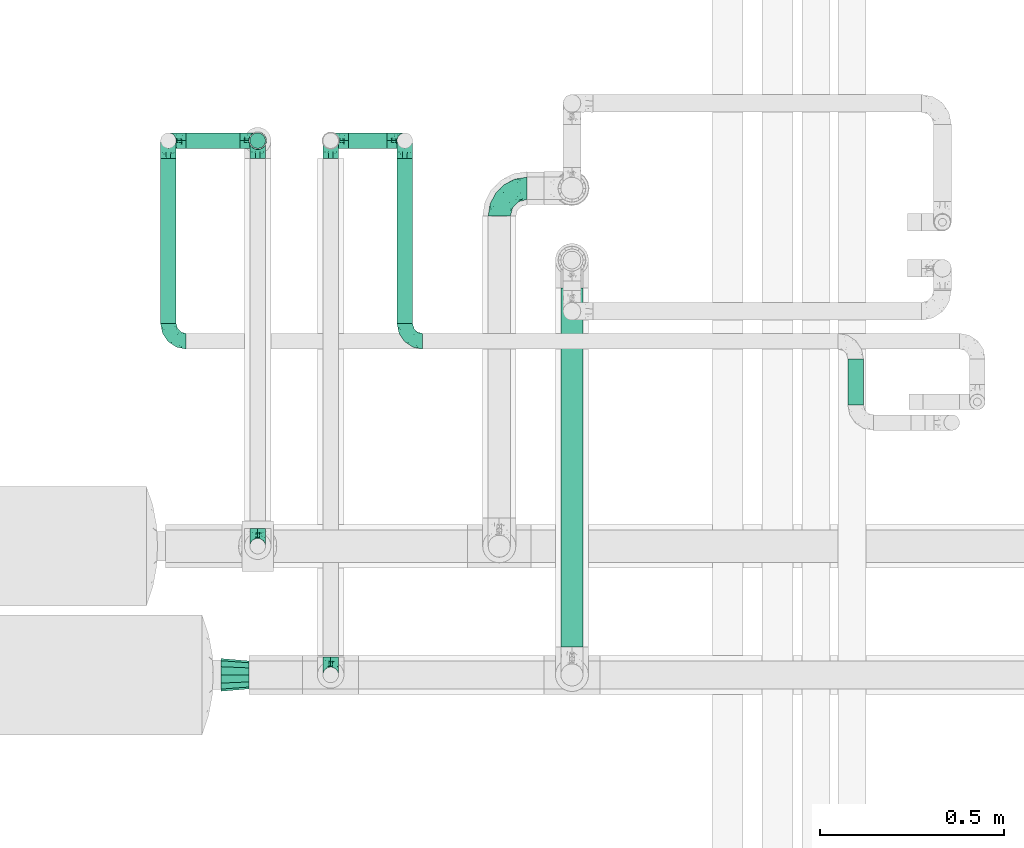
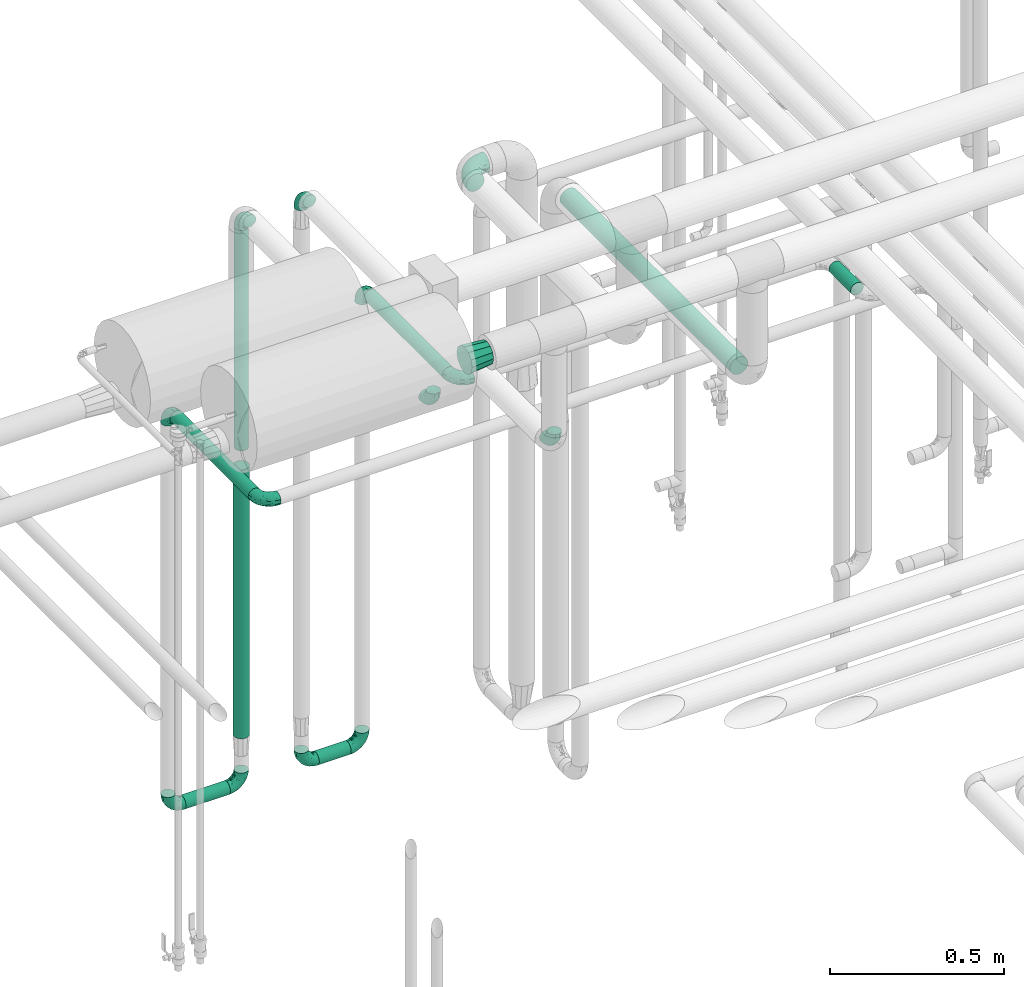
# One storey, part 573 of 824: 14 flow fittings, 8 flow segments.
"""IFC2X3 building model written with IfcOpenShell, lengths in millimetres."""

from ifc_helpers import new_model, entity, si_unit, converted_unit, derived_unit, direction, frame, origin, origin_2d_with_axis, place, context, subcontext, project, spatial, circle, extrude, faceted_brep, source, transform, mapped, material, type_object, type_shapes, element, save


model = new_model("IFC2X3")

# Units and contexts
model_context = context("Model", 3, precision=0.01, world=origin(), true_north=direction((6.12303176911189e-17, 1.0)))
body_context = subcontext(model_context, "Body", "Model", "MODEL_VIEW")
ifc_project = project(units=[si_unit("LENGTHUNIT", "METRE", prefix="MILLI"), si_unit("AREAUNIT", "SQUARE_METRE"), si_unit("VOLUMEUNIT", "CUBIC_METRE"), converted_unit("PLANEANGLEUNIT", "DEGREE", entity("IfcRatioMeasure", 0.0174532925199433), si_unit("PLANEANGLEUNIT", "RADIAN"), dimensions=[0, 0, 0, 0, 0, 0, 0]), si_unit("MASSUNIT", "GRAM", prefix="KILO"), derived_unit("MASSDENSITYUNIT", [(si_unit("MASSUNIT", "GRAM", prefix="KILO"), 1), (si_unit("LENGTHUNIT", "METRE"), -3)]), derived_unit("MOMENTOFINERTIAUNIT", [(si_unit("LENGTHUNIT", "METRE"), 4)]), si_unit("TIMEUNIT", "SECOND"), si_unit("FREQUENCYUNIT", "HERTZ"), si_unit("THERMODYNAMICTEMPERATUREUNIT", "DEGREE_CELSIUS"), derived_unit("THERMALTRANSMITTANCEUNIT", [(si_unit("MASSUNIT", "GRAM", prefix="KILO"), 1), (si_unit("THERMODYNAMICTEMPERATUREUNIT", "KELVIN"), -1), (si_unit("TIMEUNIT", "SECOND"), -3)]), derived_unit("VOLUMETRICFLOWRATEUNIT", [(si_unit("LENGTHUNIT", "METRE"), 3), (si_unit("TIMEUNIT", "SECOND"), -1)]), derived_unit("MASSFLOWRATEUNIT", [(si_unit("MASSUNIT", "GRAM", prefix="KILO"), 1), (si_unit("TIMEUNIT", "SECOND"), -1)]), derived_unit("ROTATIONALFREQUENCYUNIT", [(si_unit("TIMEUNIT", "SECOND"), -1)]), si_unit("ELECTRICCURRENTUNIT", "AMPERE"), si_unit("ELECTRICVOLTAGEUNIT", "VOLT"), si_unit("POWERUNIT", "WATT"), si_unit("FORCEUNIT", "NEWTON", prefix="KILO"), si_unit("ILLUMINANCEUNIT", "LUX"), si_unit("LUMINOUSFLUXUNIT", "LUMEN"), si_unit("LUMINOUSINTENSITYUNIT", "CANDELA"), derived_unit("USERDEFINED", [(si_unit("MASSUNIT", "GRAM", prefix="KILO"), -1), (si_unit("LENGTHUNIT", "METRE"), -2), (si_unit("TIMEUNIT", "SECOND"), 3), (si_unit("LUMINOUSFLUXUNIT", "LUMEN"), 1)]), derived_unit("LINEARVELOCITYUNIT", [(si_unit("LENGTHUNIT", "METRE"), 1), (si_unit("TIMEUNIT", "SECOND"), -1)]), si_unit("PRESSUREUNIT", "PASCAL"), derived_unit("USERDEFINED", [(si_unit("LENGTHUNIT", "METRE"), -2), (si_unit("MASSUNIT", "GRAM", prefix="KILO"), 1), (si_unit("TIMEUNIT", "SECOND"), -2)]), derived_unit("LINEARFORCEUNIT", [(si_unit("MASSUNIT", "GRAM", prefix="KILO"), 1), (si_unit("LENGTHUNIT", "METRE"), 1), (si_unit("TIMEUNIT", "SECOND"), -2), (si_unit("LENGTHUNIT", "METRE"), -1)]), derived_unit("PLANARFORCEUNIT", [(si_unit("MASSUNIT", "GRAM", prefix="KILO"), 1), (si_unit("LENGTHUNIT", "METRE"), 1), (si_unit("TIMEUNIT", "SECOND"), -2), (si_unit("LENGTHUNIT", "METRE"), -2)])], contexts=[model_context])

# Site, building, storey
site_placement = place(None, origin())
site = spatial("IfcSite", under=ifc_project, at=site_placement, CompositionType="ELEMENT")
building_placement = place(site_placement, origin())
building = spatial("IfcBuilding", under=site, at=building_placement, CompositionType="ELEMENT")
storey_placement = place(building_placement, frame((0.0, 0.0, 28200.0)))
storey = spatial("IfcBuildingStorey", under=building, at=storey_placement, CompositionType="ELEMENT", Elevation=28200.0)

# Flow segments
pipe_segment_type = type_object("IfcPipeSegmentType", PredefinedType="NOTDEFINED")
flow_segment_1_placement = place(storey_placement, frame((17314.71, 15829.04, 381.11)))
element("IfcFlowSegment", 1, at=flow_segment_1_placement, inside=storey, type_object=pipe_segment_type, context=body_context, shape_type="SweptSolid", body=[
    extrude(circle(Radius=21.15, at=origin_2d_with_axis()), frame((0.0, 22.75, 22.75), z_axis=(1.0, 0.0, 0.0), x_axis=(0.0, -1.0, 0.0)), (0.0, 0.0, 1.0), 105.488840849872),
])
flow_segment_2_placement = place(storey_placement, frame((16873.63, 15829.04, 381.19)))
element("IfcFlowSegment", 2, at=flow_segment_2_placement, inside=storey, type_object=pipe_segment_type, context=body_context, shape_type="SweptSolid", body=[
    extrude(circle(Radius=21.15, at=origin_2d_with_axis()), frame((0.0, 22.75, 22.75), z_axis=(1.0, 0.0, 0.0), x_axis=(0.0, -1.0, 0.0)), (0.0, 0.0, 1.0), 146.73003738029),
])
flow_segment_3_placement = place(storey_placement, frame((18670.46, 15133.74, 1977.25)))
element("IfcFlowSegment", 3, at=flow_segment_3_placement, inside=storey, type_object=pipe_segment_type, context=body_context, shape_type="SweptSolid", body=[
    extrude(circle(Radius=21.15, at=origin_2d_with_axis()), frame((22.75, 0.0, 22.75), z_axis=(0.0, 1.0, 0.0), x_axis=(-1.0, 0.0, 0.0)), (0.0, 0.0, 1.0), 125.041289846792),
])
flow_segment_4_placement = place(storey_placement, frame((17045.62, 15829.04, 1580.0)))
element("IfcFlowSegment", 4, at=flow_segment_4_placement, inside=storey, type_object=pipe_segment_type, context=body_context, shape_type="SweptSolid", body=[
    extrude(circle(Radius=21.15, at=origin_2d_with_axis()), frame((22.75, 22.75, 0.0)), (0.0, 0.0, 1.0), 772.000000000002),
])
flow_segment_5_placement = place(storey_placement, frame((17890.7, 14476.0, 2368.4)))
element("IfcFlowSegment", 5, at=flow_segment_5_placement, inside=storey, type_object=pipe_segment_type, context=body_context, shape_type="SweptSolid", body=[
    extrude(circle(Radius=30.0, at=origin_2d_with_axis()), frame((31.6, 0.0, 31.6), z_axis=(0.0, 1.0, 0.0), x_axis=(-1.0, 0.0, 0.0)), (0.0, 0.0, 1.0), 975.249133388721),
])
flow_segment_6_placement = place(storey_placement, frame((17042.77, 15826.19, 574.2)))
element("IfcFlowSegment", 6, at=flow_segment_6_placement, inside=storey, type_object=pipe_segment_type, context=body_context, shape_type="SweptSolid", body=[
    extrude(circle(Radius=24.0, at=origin_2d_with_axis()), frame((25.6, 25.6, 0.0)), (0.0, 0.0, 1.0), 941.79999999999),
])
flow_segment_7_placement = place(storey_placement, frame((17445.46, 15354.79, 1977.25)))
element("IfcFlowSegment", 7, at=flow_segment_7_placement, inside=storey, type_object=pipe_segment_type, context=body_context, shape_type="SweptSolid", body=[
    extrude(circle(Radius=21.15, at=origin_2d_with_axis()), frame((22.75, 0.0, 22.75), z_axis=(0.0, 1.0, 0.0), x_axis=(1.0, 0.0, 0.0)), (0.0, 0.0, 1.0), 448.999348960777),
])
flow_segment_8_placement = place(storey_placement, frame((16802.89, 15354.79, 1777.25)))
element("IfcFlowSegment", 8, at=flow_segment_8_placement, inside=storey, type_object=pipe_segment_type, context=body_context, shape_type="SweptSolid", body=[
    extrude(circle(Radius=21.15, at=origin_2d_with_axis()), frame((22.75, 0.0, 22.75), z_axis=(0.0, 1.0, 0.0), x_axis=(1.0, 0.0, 0.0)), (0.0, 0.0, 1.0), 448.999348960775),
])

# Flow fittings
ifc_material = material()
pipe_fitting_type_1 = type_object("IfcPipeFittingType", PredefinedType="NOTDEFINED", material=ifc_material)
shared_shape_1 = source(origin(), body_context, "Body", "Brep", [
    faceted_brep([(-48.0, 10.6, -18.36), (-48.0, 5.49, -20.48), (-48.0, 0.0, -21.2), (-48.0, -5.49, -20.48), (-48.0, -10.6, -18.36), (-48.0, -14.99, -14.99), (-48.0, -18.36, -10.6), (-48.0, -20.48, -5.49), (-48.0, -21.2, 0.0), (-48.0, -20.48, 5.49), (-48.0, -18.36, 10.6), (-48.0, -14.99, 14.99), (-48.0, -10.6, 18.36), (-48.0, -5.49, 20.48), (-48.0, 0.0, 21.2), (-48.0, 5.49, 20.48), (-48.0, 10.6, 18.36), (-48.0, 14.99, 14.99), (-48.0, 18.36, 10.6), (-48.0, 20.48, 5.49), (-48.0, 21.2, 0.0), (-48.0, 20.48, -5.49), (-48.0, 18.36, -10.6), (-48.0, 14.99, -14.99), (0.0, 48.0, -21.2), (-5.49, 48.0, -20.48), (-10.6, 48.0, -18.36), (-14.99, 48.0, -14.99), (-18.36, 48.0, -10.6), (-20.48, 48.0, -5.49), (-21.2, 48.0, 0.0), (-20.48, 48.0, 5.49), (-18.36, 48.0, 10.6), (-14.99, 48.0, 14.99), (-10.6, 48.0, 18.36), (-5.49, 48.0, 20.48), (0.0, 48.0, 21.2), (5.49, 48.0, 20.48), (10.6, 48.0, 18.36), (14.99, 48.0, 14.99), (18.36, 48.0, 10.6), (20.48, 48.0, 5.49), (21.2, 48.0, 0.0), (20.48, 48.0, -5.49), (18.36, 48.0, -10.6), (14.99, 48.0, -14.99), (10.6, 48.0, -18.36), (5.49, 48.0, -20.48), (-35.25, -16.22, 12.01), (-34.76, -18.57, 0.0), (-20.87, -12.37, 10.9), (-31.49, -11.78, 15.9), (-37.0, -2.58, 20.86), (-33.89, 3.62, 21.15), (-31.81, -18.14, 6.76), (-5.78, 5.78, 17.67), (-19.42, -4.1, 17.86), (-9.6, -3.39, 13.73), (-35.44, -7.73, 19.13), (11.78, 31.49, 15.9), (-5.93, -5.46, 6.95), (-18.45, -13.78, 5.46), (-10.29, -8.43, 0.0), (-24.6, 0.55, 20.62), (-37.28, 17.94, 13.81), (-33.38, 22.85, 9.59), (-41.46, 20.06, 8.75), (-29.51, 20.45, 15.16), (-15.04, 10.79, 21.13), (-7.08, 16.98, 20.93), (-8.39, 23.51, 21.15), (-40.86, 13.03, 17.26), (-8.05, 41.26, 19.83), (-3.21, 35.97, 21.14), (8.53, 19.66, 14.74), (4.1, 19.42, 17.86), (-37.72, 22.66, 4.78), (-37.07, 8.58, 19.98), (-13.0, 5.43, 19.97), (-3.78, 13.93, 19.7), (3.02, 8.69, 13.43), (-2.27, -0.05, 10.65), (6.22, 6.99, 7.09), (-22.25, 34.6, 9.45), (18.14, 31.81, 6.76), (16.22, 35.25, 12.01), (12.37, 20.87, 10.9), (7.73, 35.44, 19.13), (-21.52, -15.93, 0.0), (2.58, 37.0, 20.86), (18.57, 34.76, 0.0), (13.78, 18.45, 5.46), (15.93, 21.52, 0.0), (-20.03, -8.54, 14.9), (-28.6, 28.6, 5.16), (-24.79, 34.6, 0.0), (-34.6, 24.79, 0.0), (-22.81, 37.41, 4.68), (-23.36, 26.33, 14.79), (-13.68, 37.05, 17.49), (-17.72, 38.12, 13.73), (-26.25, 27.3, 11.24), (-9.71, 32.34, 20.14), (-17.26, 25.6, 18.71), (-26.33, 9.99, 20.77), (-24.06, 6.05, 21.2), (-25.02, 15.46, 19.56), (-24.3, 20.72, 17.57), (-31.95, 15.23, 17.8), (-13.53, 24.7, 20.21), (-17.6, 17.6, 20.6), (-0.55, 24.6, 20.62), (-11.41, -7.48, 10.43), (0.93, -0.93, 0.0), (8.43, 10.29, 0.0), (-11.41, -7.48, -10.43), (-20.1, -8.84, -14.66), (-9.6, -3.39, -13.73), (7.73, 35.44, -19.13), (4.1, 19.42, -17.86), (-0.55, 24.6, -20.62), (-38.12, 17.72, -13.73), (-37.05, 13.68, -17.49), (-32.34, 9.71, -20.14), (-41.26, 8.05, -19.83), (-37.41, 22.81, -4.68), (-23.51, 8.39, -21.15), (-35.97, 3.21, -21.14), (-28.6, 28.6, -5.16), (-31.81, -18.14, -6.76), (-18.45, -13.78, -5.46), (-25.6, 17.26, -18.71), (-19.42, -4.1, -17.86), (-17.94, 37.28, -13.81), (-22.85, 33.38, -9.59), (-20.06, 41.46, -8.75), (-31.49, -11.78, -15.9), (-35.25, -16.22, -12.01), (8.53, 19.66, -14.74), (11.78, 31.49, -15.9), (-9.99, 26.33, -20.77), (-6.05, 24.06, -21.2), (-10.79, 15.04, -21.13), (-37.0, -2.58, -20.86), (-16.98, 7.08, -20.93), (-5.43, 13.0, -19.97), (-13.93, 3.78, -19.7), (-20.87, -12.37, -10.9), (-26.33, 23.36, -14.79), (-22.66, 37.72, -4.78), (13.78, 18.45, -5.46), (18.14, 31.81, -6.76), (-15.46, 25.02, -19.56), (-20.72, 24.3, -17.57), (16.22, 35.25, -12.01), (-13.03, 40.86, -17.26), (-8.58, 37.07, -19.98), (2.58, 37.0, -20.86), (-3.62, 33.89, -21.15), (-34.6, 22.25, -9.45), (6.22, 6.99, -7.09), (-20.45, 29.51, -15.16), (-35.44, -7.73, -19.13), (12.37, 20.87, -10.9), (-27.3, 26.25, -11.24), (-15.23, 31.95, -17.8), (-24.7, 13.53, -20.21), (-24.6, 0.55, -20.62), (-5.78, 5.78, -17.67), (-17.6, 17.6, -20.6), (3.02, 8.69, -13.43), (-5.93, -5.46, -6.95), (-2.27, -0.05, -10.65)], [[[0, 1, 2, 3, 4, 5, 6, 7, 8, 9, 10, 11, 12, 13, 14, 15, 16, 17, 18, 19, 20, 21, 22, 23]], [[24, 25, 26, 27, 28, 29, 30, 31, 32, 33, 34, 35, 36, 37, 38, 39, 40, 41, 42, 43, 44, 45, 46, 47]], [[10, 48, 11]], [[9, 8, 49]], [[48, 50, 51]], [[14, 52, 53]], [[10, 54, 48]], [[9, 54, 10]], [[55, 56, 57]], [[51, 12, 11]], [[51, 58, 12]], [[59, 39, 38]], [[60, 61, 62]], [[58, 56, 63]], [[64, 65, 66]], [[67, 65, 64]], [[68, 69, 70]], [[16, 71, 17]], [[13, 52, 14]], [[35, 72, 73]], [[14, 53, 15]], [[17, 64, 18]], [[74, 59, 75]], [[20, 19, 76]], [[66, 19, 18]], [[77, 15, 53]], [[15, 77, 16]], [[69, 78, 79]], [[80, 81, 82]], [[32, 31, 83]], [[84, 85, 86]], [[59, 87, 75]], [[61, 54, 88]], [[36, 89, 37]], [[84, 41, 40]], [[36, 35, 73]], [[90, 41, 84]], [[40, 39, 85]], [[12, 58, 13]], [[85, 84, 40]], [[91, 84, 86]], [[84, 92, 90]], [[87, 38, 37]], [[93, 56, 51]], [[65, 94, 76]], [[94, 95, 96]], [[84, 91, 92]], [[95, 97, 30]], [[98, 99, 100]], [[76, 94, 96]], [[101, 98, 83]], [[100, 99, 33]], [[102, 70, 73]], [[103, 102, 99]], [[94, 97, 95]], [[72, 99, 102]], [[72, 35, 34]], [[34, 33, 99]], [[9, 49, 54]], [[87, 59, 38]], [[104, 105, 68]], [[106, 103, 107]], [[106, 77, 104]], [[71, 64, 17]], [[108, 107, 67]], [[33, 32, 100]], [[109, 103, 110]], [[102, 109, 70]], [[89, 73, 111]], [[50, 48, 54]], [[51, 11, 48]], [[56, 58, 51]], [[88, 54, 49]], [[52, 58, 63]], [[50, 112, 93]], [[56, 55, 78]], [[39, 59, 85]], [[86, 85, 59]], [[89, 87, 37]], [[42, 41, 90]], [[111, 79, 75]], [[111, 75, 87]], [[75, 55, 80]], [[104, 77, 53]], [[71, 77, 108]], [[32, 83, 100]], [[98, 100, 83]], [[99, 98, 103]], [[106, 107, 108]], [[68, 70, 110]], [[111, 73, 70]], [[68, 110, 104]], [[68, 63, 78]], [[57, 93, 112]], [[80, 55, 57]], [[61, 50, 54]], [[80, 82, 86]], [[81, 57, 112]], [[74, 86, 59]], [[60, 113, 82]], [[82, 114, 91]], [[101, 94, 65]], [[97, 94, 83]], [[73, 89, 36]], [[87, 89, 111]], [[58, 52, 13]], [[53, 52, 63]], [[104, 53, 105]], [[106, 104, 110]], [[20, 76, 96]], [[76, 19, 66]], [[103, 106, 110]], [[77, 106, 108]], [[103, 98, 107]], [[67, 107, 98]], [[67, 98, 101]], [[108, 67, 64]], [[53, 63, 105]], [[63, 68, 105]], [[83, 31, 97]], [[30, 97, 31]], [[62, 113, 60]], [[112, 61, 60]], [[61, 88, 62]], [[86, 82, 91]], [[56, 78, 63]], [[114, 82, 113]], [[114, 92, 91]], [[79, 78, 55]], [[75, 79, 55]], [[69, 79, 111]], [[70, 69, 111]], [[78, 69, 68]], [[77, 71, 16]], [[64, 71, 108]], [[64, 66, 18]], [[76, 66, 65]], [[99, 72, 34]], [[73, 72, 102]], [[94, 101, 83]], [[67, 101, 65]], [[75, 80, 74]], [[80, 86, 74]], [[70, 109, 110]], [[102, 103, 109]], [[50, 93, 51]], [[57, 56, 93]], [[61, 112, 50]], [[81, 112, 60]], [[82, 81, 60]], [[80, 57, 81]], [[115, 116, 117]], [[118, 119, 120]], [[121, 122, 23]], [[123, 124, 122]], [[96, 125, 20]], [[123, 126, 127]], [[128, 96, 95]], [[129, 130, 88]], [[123, 122, 131]], [[116, 132, 117]], [[133, 134, 135]], [[0, 124, 1]], [[5, 136, 137]], [[138, 119, 139]], [[129, 88, 49]], [[140, 141, 142]], [[6, 5, 137]], [[46, 118, 47]], [[143, 3, 2]], [[144, 145, 146]], [[6, 129, 7]], [[129, 137, 147]], [[127, 2, 1]], [[148, 122, 121]], [[128, 125, 96]], [[134, 128, 149]], [[95, 149, 128]], [[150, 151, 92]], [[30, 29, 149]], [[152, 131, 153]], [[27, 133, 28]], [[154, 45, 44]], [[136, 5, 4]], [[27, 26, 155]], [[156, 26, 25]], [[24, 157, 158]], [[24, 47, 157]], [[22, 21, 159]], [[160, 150, 114]], [[134, 133, 161]], [[142, 144, 126]], [[46, 139, 118]], [[162, 136, 4]], [[156, 25, 158]], [[1, 124, 127]], [[115, 147, 116]], [[45, 154, 139]], [[139, 46, 45]], [[154, 163, 139]], [[162, 4, 3]], [[42, 90, 43]], [[130, 129, 147]], [[49, 7, 129]], [[43, 151, 44]], [[0, 23, 122]], [[24, 158, 25]], [[136, 162, 132]], [[135, 29, 28]], [[43, 90, 151]], [[164, 148, 159]], [[152, 156, 140]], [[155, 133, 27]], [[165, 153, 161]], [[23, 22, 121]], [[123, 131, 166]], [[123, 166, 126]], [[143, 127, 167]], [[147, 137, 136]], [[8, 7, 49]], [[129, 6, 137]], [[143, 162, 3]], [[167, 146, 132]], [[167, 132, 162]], [[132, 168, 117]], [[44, 151, 154]], [[92, 151, 90]], [[163, 154, 151]], [[119, 118, 139]], [[157, 118, 120]], [[138, 139, 163]], [[119, 168, 145]], [[140, 156, 158]], [[155, 156, 165]], [[22, 159, 121]], [[148, 121, 159]], [[122, 148, 131]], [[152, 153, 165]], [[142, 126, 169]], [[167, 127, 126]], [[142, 169, 140]], [[142, 120, 145]], [[168, 170, 117]], [[160, 171, 172]], [[115, 172, 171]], [[171, 62, 130]], [[119, 170, 168]], [[170, 163, 160]], [[150, 163, 151]], [[113, 171, 160]], [[164, 128, 134]], [[125, 128, 159]], [[127, 143, 2]], [[162, 143, 167]], [[118, 157, 47]], [[158, 157, 120]], [[140, 158, 141]], [[152, 140, 169]], [[30, 149, 95]], [[149, 29, 135]], [[131, 152, 169]], [[156, 152, 165]], [[131, 148, 153]], [[161, 153, 148]], [[161, 148, 164]], [[165, 161, 133]], [[158, 120, 141]], [[120, 142, 141]], [[159, 21, 125]], [[20, 125, 21]], [[115, 130, 147]], [[114, 113, 160]], [[62, 171, 113]], [[62, 88, 130]], [[160, 163, 150]], [[150, 92, 114]], [[119, 145, 120]], [[146, 145, 168]], [[132, 146, 168]], [[144, 146, 167]], [[126, 144, 167]], [[145, 144, 142]], [[156, 155, 26]], [[133, 155, 165]], [[133, 135, 28]], [[149, 135, 134]], [[122, 124, 0]], [[127, 124, 123]], [[128, 164, 159]], [[161, 164, 134]], [[163, 170, 138]], [[170, 119, 138]], [[131, 169, 166]], [[126, 166, 169]], [[147, 136, 116]], [[132, 116, 136]], [[172, 115, 117]], [[130, 115, 171]], [[117, 170, 172]], [[160, 172, 170]]]),
])
type_shapes(pipe_fitting_type_1, [shared_shape_1])
for number, where, z_axis, x_axis in (
    (9, (17068.36, 15851.79, 403.94), (0.0, -1.0, 0.0), (1.0, 0.0, 0.0)),
    (10, (17266.71, 15851.79, 403.86), (0.0, 1.0, 0.0), (-1.0, 0.0, 0.0)),
    (11, (16825.63, 15851.79, 403.94), (0.0, 1.0, 0.0), (-1.0, 0.0, 0.0)),
    (12, (17468.2, 15851.79, 403.86), (0.0, -1.0, 0.0), (1.0, 0.0, 0.0)),
    (13, (17068.36, 15851.79, 2400.0), (1.0, 0.0, 0.0), (0.0, 0.0, 1.0)),
    (14, (17068.36, 14749.79, 2400.0), (1.0, 0.0, 0.0), (0.0, 0.0, -1.0)),
    (15, (17266.71, 14400.0, 2400.0), (1.0, 0.0, 0.0), (0.0, 0.0, -1.0)),
    (16, (17266.71, 15851.79, 2400.0), (1.0, 0.0, 0.0), (0.0, 0.0, 1.0)),
    (17, (17468.2, 15306.79, 2000.0), (0.0, 0.0, 1.0), (0.0, -1.0, 0.0)),
    (18, (17468.2, 15851.79, 2000.0), (1.0, 0.0, 0.0), (0.0, 0.0, 1.0)),
    (19, (16825.63, 15306.79, 1800.0), (0.0, 0.0, 1.0), (0.0, -1.0, 0.0)),
    (20, (16825.63, 15851.79, 1800.0), (1.0, 0.0, 0.0), (0.0, 0.0, 1.0)),
):
    element("IfcFlowFitting", number, at=place(storey_placement, frame(where, z_axis=z_axis, x_axis=x_axis)), inside=storey, type_object=pipe_fitting_type_1, material=ifc_material, context=body_context, shape_type="MappedRepresentation", body=[
        mapped(shared_shape_1, transform((0.0, 0.0, 0.0), scale=1.0)),
    ])
pipe_fitting_type_2 = type_object("IfcPipeFittingType", PredefinedType="NOTDEFINED", material=ifc_material)
shared_shape_2 = source(origin(), body_context, "Body", "Brep", [
    faceted_brep([(-76.0, 15.07, -26.11), (-76.0, 7.8, -29.12), (-76.0, 0.0, -30.15), (-76.0, -7.8, -29.12), (-76.0, -15.08, -26.11), (-76.0, -21.32, -21.32), (-76.0, -26.11, -15.08), (-76.0, -29.12, -7.8), (-76.0, -30.15, 0.0), (-76.0, -29.12, 7.8), (-76.0, -26.11, 15.07), (-76.0, -21.32, 21.32), (-76.0, -15.08, 26.11), (-76.0, -7.8, 29.12), (-76.0, 0.0, 30.15), (-76.0, 7.8, 29.12), (-76.0, 15.07, 26.11), (-76.0, 21.32, 21.32), (-76.0, 26.11, 15.07), (-76.0, 29.12, 7.8), (-76.0, 30.15, 0.0), (-76.0, 29.12, -7.8), (-76.0, 26.11, -15.08), (-76.0, 21.32, -21.32), (0.0, 76.0, -30.15), (-7.8, 76.0, -29.12), (-15.07, 76.0, -26.11), (-21.32, 76.0, -21.32), (-26.11, 76.0, -15.08), (-29.12, 76.0, -7.8), (-30.15, 76.0, 0.0), (-29.12, 76.0, 7.8), (-26.11, 76.0, 15.07), (-21.32, 76.0, 21.32), (-15.07, 76.0, 26.11), (-7.8, 76.0, 29.12), (0.0, 76.0, 30.15), (7.8, 76.0, 29.12), (15.08, 76.0, 26.11), (21.32, 76.0, 21.32), (26.11, 76.0, 15.07), (29.12, 76.0, 7.8), (30.15, 76.0, 0.0), (29.12, 76.0, -7.8), (26.11, 76.0, -15.08), (21.32, 76.0, -21.32), (15.08, 76.0, -26.11), (7.8, 76.0, -29.12), (10.79, 31.43, 21.07), (4.32, 31.7, 25.72), (1.65, 15.19, 19.92), (-61.17, -27.8, 0.0), (-51.1, -25.49, 9.84), (-56.14, -10.61, 27.27), (-31.7, -4.32, 25.72), (-39.75, 1.72, 29.41), (-43.2, -24.95, 0.0), (-1.86, 1.86, 0.0), (4.49, 7.65, 5.78), (-7.82, -4.61, 5.83), (-56.21, -22.79, 17.21), (-58.98, -3.38, 29.7), (-53.96, 5.6, 30.07), (-10.86, 10.86, 25.48), (-17.2, -2.6, 20.44), (-49.15, -16.01, 22.7), (-22.18, -14.24, 7.99), (-28.4, -17.42, 0.0), (-13.61, -9.88, 0.0), (-39.0, 23.48, 27.76), (-58.76, 12.54, 28.36), (-41.61, 15.41, 29.48), (16.01, 49.15, 22.7), (-58.55, 25.93, 19.53), (-51.53, 33.5, 13.51), (-64.92, 28.76, 12.4), (-7.48, 23.14, 28.25), (-1.72, 39.75, 29.41), (-12.04, 27.88, 29.88), (-63.91, 18.81, 24.52), (-11.63, 65.16, 28.18), (-4.97, 57.02, 30.05), (9.88, 13.61, 0.0), (-62.5, 31.74, 5.02), (-45.17, 30.98, 21.2), (-21.78, 9.76, 28.58), (10.61, 56.14, 27.27), (-32.09, 54.42, 13.26), (22.79, 56.21, 17.21), (15.38, 31.17, 15.63), (25.49, 51.1, 9.84), (21.84, 36.35, 5.92), (24.95, 43.2, 0.0), (3.38, 58.98, 29.7), (-31.17, -15.38, 15.63), (-39.39, 41.78, 15.45), (-34.56, 41.13, 20.79), (-39.81, -23.25, 5.49), (27.8, 61.17, 0.0), (-31.74, 62.5, 5.02), (-53.07, 36.29, 0.0), (-42.95, 42.95, 7.29), (-36.29, 53.07, 0.0), (-19.83, 58.51, 24.79), (-25.48, 60.2, 19.41), (-14.53, 50.96, 28.57), (-13.31, 37.09, 30.07), (-26.16, 40.06, 26.4), (-32.43, -10.35, 21.9), (17.42, 28.4, 0.0), (14.24, 22.18, 7.99), (-38.67, 9.72, 30.15), (-24.66, 17.36, 30.09), (-37.08, 31.49, 24.99), (-49.27, 22.83, 25.24), (-20.8, 38.81, 28.63), (-27.58, 27.58, 29.2), (-36.07, -20.23, 10.71), (-15.19, -6.16, 14.9), (6.6, 15.4, 14.49), (-2.51, 2.51, 11.35), (-65.16, 11.63, -28.18), (-49.15, -16.01, -22.7), (-57.02, 4.97, -30.05), (-25.93, 58.55, -19.53), (-33.5, 51.53, -13.51), (-28.76, 64.92, -12.4), (-60.2, 25.48, -19.41), (-58.51, 19.83, -24.79), (4.61, 7.82, -5.83), (-7.65, -4.49, -5.78), (-2.51, 2.51, -11.35), (-62.5, 31.74, -5.02), (-50.96, 14.53, -28.57), (-37.09, 13.31, -30.07), (-42.95, 42.95, -7.29), (25.49, 51.1, -9.84), (22.79, 56.21, -17.21), (-40.06, 26.16, -26.4), (3.38, 58.98, -29.7), (-5.6, 53.96, -30.07), (-27.88, 12.04, -29.88), (-9.76, 21.78, -28.58), (-23.14, 7.48, -28.25), (-51.1, -25.49, -9.84), (15.38, 31.17, -15.63), (16.01, 49.15, -22.7), (-23.48, 39.0, -27.76), (-12.54, 58.76, -28.36), (-15.41, 41.61, -29.48), (-56.21, -22.79, -17.21), (-9.72, 38.67, -30.15), (-17.36, 24.66, -30.09), (-22.18, -14.24, -7.99), (-41.13, 34.56, -20.79), (-31.74, 62.5, -5.02), (-58.98, -3.38, -29.7), (-31.17, -15.38, -15.63), (-56.14, -10.61, -27.27), (14.24, 22.18, -7.99), (23.25, 39.81, -5.49), (-31.49, 37.08, -24.99), (-15.19, -6.16, -14.9), (1.65, 15.19, -19.92), (-18.81, 63.91, -24.52), (-32.59, -11.62, -20.84), (-31.7, -4.32, -25.72), (-17.2, -2.6, -20.44), (-39.75, 1.72, -29.41), (-54.42, 32.09, -13.26), (-30.98, 45.17, -21.2), (10.61, 56.14, -27.27), (10.23, 31.31, -21.52), (4.32, 31.7, -25.72), (-41.78, 39.39, -15.45), (-1.72, 39.75, -29.41), (-36.35, -21.84, -5.92), (-22.83, 49.27, -25.24), (-38.81, 20.8, -28.63), (-27.58, 27.58, -29.2), (-10.86, 10.86, -25.48), (20.23, 36.07, -10.71), (6.6, 15.4, -14.49)], [[[0, 1, 2, 3, 4, 5, 6, 7, 8, 9, 10, 11, 12, 13, 14, 15, 16, 17, 18, 19, 20, 21, 22, 23]], [[24, 25, 26, 27, 28, 29, 30, 31, 32, 33, 34, 35, 36, 37, 38, 39, 40, 41, 42, 43, 44, 45, 46, 47]], [[48, 49, 50]], [[51, 52, 9]], [[53, 54, 55]], [[9, 52, 10]], [[56, 52, 51]], [[57, 58, 59]], [[11, 10, 60]], [[14, 61, 62]], [[63, 54, 64]], [[65, 12, 11]], [[65, 53, 12]], [[66, 67, 68]], [[69, 70, 71]], [[72, 39, 38]], [[73, 74, 75]], [[15, 70, 16]], [[76, 77, 78]], [[16, 79, 17]], [[13, 61, 14]], [[35, 80, 81]], [[14, 62, 15]], [[17, 73, 18]], [[57, 82, 58]], [[20, 19, 83]], [[75, 19, 18]], [[70, 15, 62]], [[73, 84, 74]], [[78, 85, 76]], [[38, 86, 72]], [[32, 31, 87]], [[88, 89, 90]], [[91, 92, 90]], [[72, 86, 49]], [[36, 93, 37]], [[75, 83, 19]], [[36, 35, 81]], [[60, 94, 65]], [[40, 90, 41]], [[95, 96, 87]], [[88, 90, 40]], [[66, 97, 67]], [[90, 98, 41]], [[40, 39, 88]], [[99, 31, 30]], [[20, 83, 100]], [[101, 102, 100]], [[52, 60, 10]], [[102, 99, 30]], [[96, 103, 104]], [[83, 101, 100]], [[12, 53, 13]], [[104, 103, 33]], [[105, 106, 81]], [[107, 105, 103]], [[64, 54, 108]], [[80, 103, 105]], [[80, 35, 34]], [[34, 33, 103]], [[86, 38, 37]], [[109, 110, 82]], [[71, 111, 112]], [[69, 107, 113]], [[79, 73, 17]], [[114, 113, 84]], [[33, 32, 104]], [[115, 107, 116]], [[105, 115, 106]], [[93, 81, 77]], [[54, 53, 65]], [[61, 53, 55]], [[108, 94, 64]], [[54, 63, 85]], [[93, 86, 37]], [[77, 76, 49]], [[77, 49, 86]], [[49, 63, 50]], [[60, 52, 117]], [[65, 11, 60]], [[39, 72, 88]], [[89, 88, 72]], [[71, 70, 62]], [[79, 70, 114]], [[103, 96, 107]], [[69, 113, 114]], [[112, 106, 116]], [[77, 81, 106]], [[112, 116, 71]], [[112, 55, 85]], [[64, 50, 63]], [[57, 59, 68]], [[32, 87, 104]], [[96, 104, 87]], [[94, 118, 64]], [[50, 119, 89]], [[50, 64, 118]], [[50, 89, 48]], [[81, 93, 36]], [[86, 93, 77]], [[53, 61, 13]], [[62, 61, 55]], [[71, 62, 111]], [[69, 71, 116]], [[95, 101, 74]], [[99, 101, 87]], [[118, 66, 59]], [[117, 97, 66]], [[117, 66, 94]], [[91, 89, 110]], [[91, 110, 109]], [[110, 89, 119]], [[9, 8, 51]], [[98, 90, 92]], [[98, 42, 41]], [[101, 83, 74]], [[101, 99, 102]], [[87, 31, 99]], [[62, 55, 111]], [[55, 112, 111]], [[107, 69, 116]], [[70, 69, 114]], [[107, 96, 113]], [[84, 113, 96]], [[84, 96, 95]], [[114, 84, 73]], [[70, 79, 16]], [[73, 79, 114]], [[54, 85, 55]], [[76, 85, 63]], [[49, 76, 63]], [[77, 106, 78]], [[106, 112, 78]], [[85, 78, 112]], [[73, 75, 18]], [[83, 75, 74]], [[103, 80, 34]], [[81, 80, 105]], [[101, 95, 87]], [[84, 95, 74]], [[106, 115, 116]], [[105, 107, 115]], [[120, 59, 58]], [[82, 110, 58]], [[119, 58, 110]], [[118, 59, 120]], [[66, 68, 59]], [[54, 65, 108]], [[94, 108, 65]], [[66, 118, 94]], [[50, 118, 120]], [[50, 120, 119]], [[119, 120, 58]], [[89, 72, 48]], [[49, 48, 72]], [[60, 117, 94]], [[117, 52, 97]], [[52, 56, 97]], [[67, 97, 56]], [[92, 91, 109]], [[89, 91, 90]], [[121, 1, 0]], [[122, 5, 4]], [[2, 1, 123]], [[124, 125, 126]], [[127, 128, 23]], [[129, 130, 131]], [[100, 132, 20]], [[133, 134, 123]], [[135, 100, 102]], [[136, 137, 44]], [[133, 128, 138]], [[24, 139, 140]], [[141, 142, 143]], [[121, 128, 133]], [[6, 144, 7]], [[137, 145, 146]], [[144, 51, 7]], [[147, 148, 149]], [[144, 6, 150]], [[149, 151, 152]], [[153, 68, 67]], [[154, 128, 127]], [[30, 155, 102]], [[43, 42, 98]], [[156, 3, 2]], [[157, 144, 150]], [[158, 4, 3]], [[24, 140, 25]], [[155, 135, 102]], [[159, 160, 109]], [[30, 29, 155]], [[147, 138, 161]], [[27, 124, 28]], [[57, 129, 82]], [[162, 163, 131]], [[27, 26, 164]], [[148, 26, 25]], [[165, 166, 167]], [[24, 47, 139]], [[143, 168, 141]], [[22, 21, 169]], [[125, 124, 170]], [[148, 25, 140]], [[46, 146, 171]], [[158, 122, 4]], [[0, 23, 128]], [[1, 121, 123]], [[109, 82, 159]], [[45, 44, 137]], [[146, 46, 45]], [[136, 43, 98]], [[132, 21, 20]], [[136, 98, 92]], [[172, 173, 146]], [[46, 171, 47]], [[43, 136, 44]], [[174, 154, 169]], [[171, 173, 175]], [[6, 5, 150]], [[126, 29, 28]], [[176, 56, 144]], [[122, 158, 166]], [[164, 124, 27]], [[177, 161, 170]], [[23, 22, 127]], [[178, 138, 179]], [[133, 178, 134]], [[156, 123, 168]], [[156, 158, 3]], [[168, 143, 166]], [[168, 166, 158]], [[166, 180, 167]], [[173, 171, 146]], [[139, 171, 175]], [[172, 145, 163]], [[173, 180, 142]], [[5, 122, 150]], [[157, 150, 122]], [[137, 136, 181]], [[146, 45, 137]], [[149, 148, 140]], [[164, 148, 177]], [[128, 154, 138]], [[147, 161, 177]], [[152, 134, 179]], [[168, 123, 134]], [[152, 179, 149]], [[152, 175, 142]], [[57, 130, 129]], [[157, 165, 167]], [[22, 169, 127]], [[154, 127, 169]], [[163, 167, 180]], [[162, 157, 167]], [[173, 163, 180]], [[182, 163, 145]], [[123, 156, 2]], [[158, 156, 168]], [[171, 139, 47]], [[140, 139, 175]], [[149, 140, 151]], [[147, 149, 179]], [[174, 135, 125]], [[132, 135, 169]], [[176, 157, 153]], [[176, 153, 67]], [[153, 157, 162]], [[182, 159, 129]], [[181, 160, 159]], [[181, 159, 145]], [[51, 144, 56]], [[51, 8, 7]], [[135, 132, 100]], [[169, 21, 132]], [[126, 155, 29]], [[135, 155, 125]], [[140, 175, 151]], [[175, 152, 151]], [[138, 147, 179]], [[148, 147, 177]], [[138, 154, 161]], [[170, 161, 154]], [[170, 154, 174]], [[177, 170, 124]], [[148, 164, 26]], [[124, 164, 177]], [[173, 142, 175]], [[143, 142, 180]], [[166, 143, 180]], [[168, 134, 141]], [[134, 152, 141]], [[142, 141, 152]], [[124, 126, 28]], [[155, 126, 125]], [[128, 121, 0]], [[123, 121, 133]], [[135, 174, 169]], [[170, 174, 125]], [[134, 178, 179]], [[133, 138, 178]], [[130, 153, 162]], [[68, 153, 130]], [[57, 68, 130]], [[182, 129, 131]], [[159, 82, 129]], [[157, 122, 165]], [[166, 165, 122]], [[163, 162, 167]], [[162, 131, 130]], [[145, 172, 146]], [[163, 173, 172]], [[159, 182, 145]], [[131, 163, 182]], [[56, 176, 67]], [[157, 176, 144]], [[137, 181, 145]], [[181, 136, 160]], [[136, 92, 160]], [[109, 160, 92]]]),
])
type_shapes(pipe_fitting_type_2, [shared_shape_2])
flow_fitting_1_placement = place(storey_placement, frame((17724.74, 15722.44, 2400.16), z_axis=(0.0, -0.00205044073798272, 0.999997897844181), x_axis=(-1.0, 0.0, 0.0)))
element("IfcFlowFitting", 21, at=flow_fitting_1_placement, inside=storey, type_object=pipe_fitting_type_2, material=ifc_material, context=body_context, shape_type="MappedRepresentation", body=[
    mapped(shared_shape_2, transform((0.0, 0.0, 0.0), scale=1.0)),
])
pipe_fitting_type_3 = type_object("IfcPipeFittingType", PredefinedType="NOTDEFINED", material=ifc_material)
shared_shape_3 = source(origin(), body_context, "Body", "Brep", [
    faceted_brep([(75.0, -44.5, 0.0), (75.0, -41.54, -11.05), (75.0, -38.54, -22.25), (75.0, -30.39, -30.39), (75.0, -22.25, -38.54), (75.0, -11.13, -41.52), (75.0, 0.0, -44.5), (75.0, 11.12, -41.52), (75.0, 22.25, -38.54), (75.0, 30.39, -30.39), (75.0, 38.54, -22.25), (75.0, 41.54, -11.05), (75.0, 44.5, 0.0), (75.0, 41.54, 11.05), (75.0, 38.54, 22.25), (75.0, 30.39, 30.39), (75.0, 22.25, 38.54), (75.0, 11.12, 41.52), (75.0, 0.0, 44.5), (75.0, -11.13, 41.52), (75.0, -22.25, 38.54), (75.0, -30.39, 30.39), (75.0, -38.54, 22.25), (75.0, -41.54, 11.05), (0.0, -32.91, -19.0), (0.0, -35.45, -9.5), (0.0, -38.0, 0.0), (0.0, -35.45, 9.5), (0.0, -32.91, 19.0), (0.0, -25.95, 25.95), (0.0, -19.0, 32.91), (0.0, -9.5, 35.45), (0.0, 0.0, 38.0), (0.0, 9.5, 35.45), (0.0, 19.0, 32.91), (0.0, 25.95, 25.95), (0.0, 32.91, 19.0), (0.0, 35.45, 9.5), (0.0, 38.0, 0.0), (0.0, 35.45, -9.5), (0.0, 32.91, -19.0), (0.0, 25.95, -25.95), (0.0, 19.0, -32.91), (0.0, 9.5, -35.45), (0.0, 0.0, -38.0), (0.0, -9.5, -35.45), (0.0, -19.0, -32.91), (0.0, -25.95, -25.95)], [[[0, 1, 2, 3, 4, 5, 6, 7, 8, 9, 10, 11, 12, 13, 14, 15, 16, 17, 18, 19, 20, 21, 22, 23]], [[24, 25, 26, 27, 28, 29, 30, 31, 32, 33, 34, 35, 36, 37, 38, 39, 40, 41, 42, 43, 44, 45, 46, 47]], [[24, 47, 46, 4, 3, 2]], [[42, 8, 7, 6, 44, 43]], [[10, 40, 39, 38, 12, 11]], [[44, 6, 5, 4, 46, 45]], [[2, 1, 0, 26, 25, 24]], [[9, 8, 42, 41, 40, 10]], [[36, 35, 34, 16, 15, 14]], [[30, 20, 19, 18, 32, 31]], [[22, 28, 27, 26, 0, 23]], [[32, 18, 17, 16, 34, 33]], [[14, 13, 12, 38, 37, 36]], [[21, 20, 30, 29, 28, 22]]]),
])
type_shapes(pipe_fitting_type_3, [shared_shape_3])
flow_fitting_2_placement = place(storey_placement, frame((17044.26, 14400.0, 2799.98), z_axis=(-0.000239364731064747, -5.1338117262291e-09, 0.999999971352262), x_axis=(-0.999999970970338, -2.76378034169475e-05, -0.000239364731115215)))
element("IfcFlowFitting", 22, at=flow_fitting_2_placement, inside=storey, type_object=pipe_fitting_type_3, material=ifc_material, context=body_context, shape_type="MappedRepresentation", body=[
    mapped(shared_shape_3, transform((0.0, 0.0, 0.0), scale=1.0)),
])

save(model, "model.ifc")
